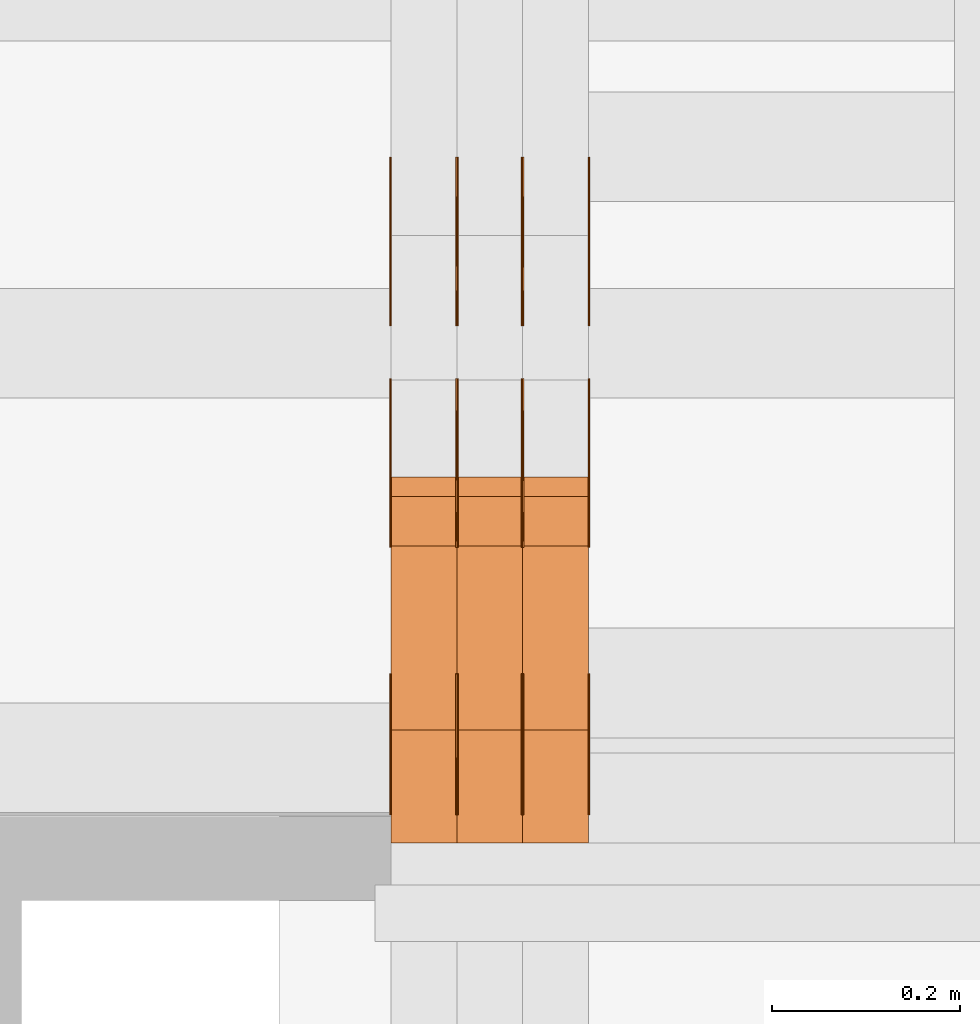
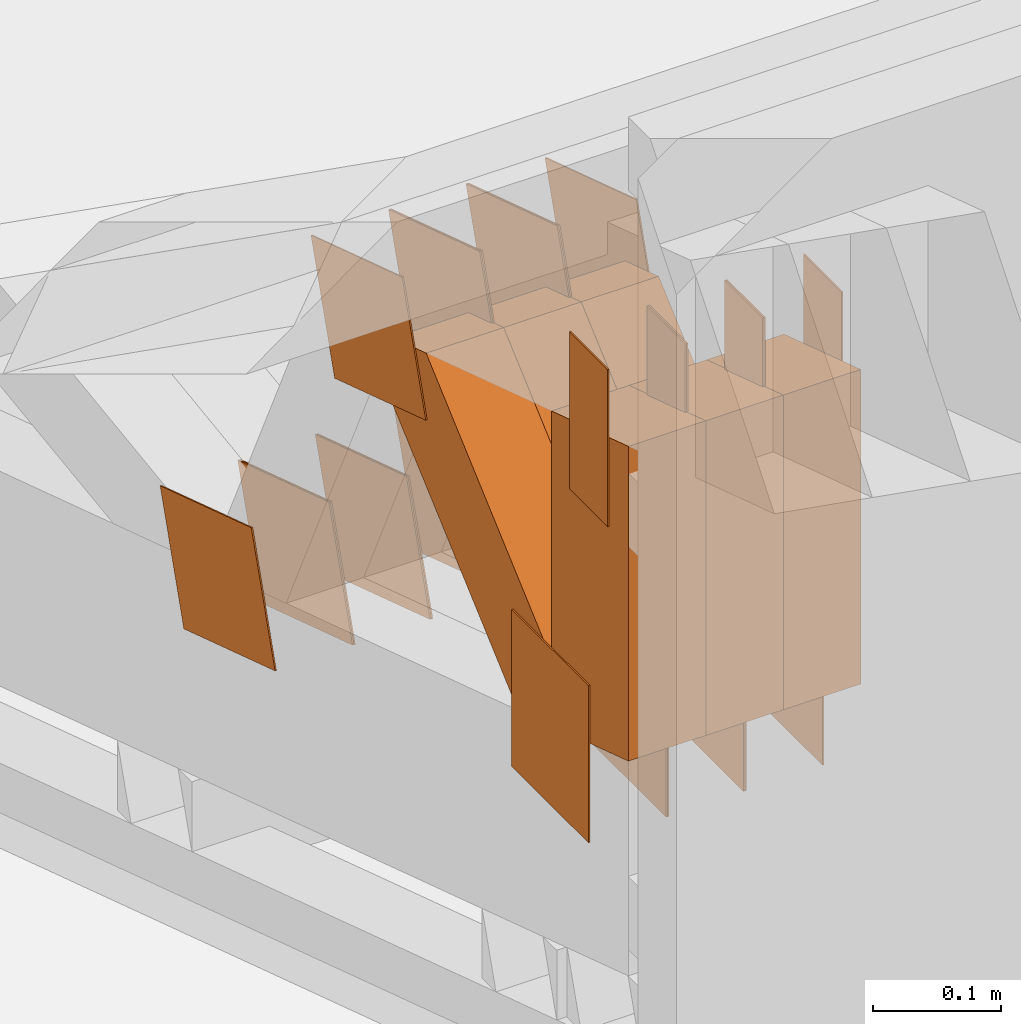
# One storey, part 82 of 385: 30 proxies.
"""IFC2X3 building model written with IfcOpenShell, lengths in millimetres."""

from ifc_helpers import new_model, entity, si_unit, converted_unit, derived_unit, direction, frame, origin, origin_2d_with_axis, place, context, subcontext, project, spatial, polyline, rectangle, outline, extrude, source, transform, mapped, material, type_object, type_shapes, element, save


model = new_model("IFC2X3")

# Units and contexts
model_context = context("Model", 3, precision=0.01, world=origin(), true_north=direction((6.12303176911189e-17, 1.0)))
body_context = subcontext(model_context, "Body", "Model", "MODEL_VIEW")
ifc_project = project(units=[si_unit("LENGTHUNIT", "METRE", prefix="MILLI"), si_unit("AREAUNIT", "SQUARE_METRE"), si_unit("VOLUMEUNIT", "CUBIC_METRE"), converted_unit("PLANEANGLEUNIT", "DEGREE", entity("IfcRatioMeasure", 0.0174532925199433), si_unit("PLANEANGLEUNIT", "RADIAN"), dimensions=[0, 0, 0, 0, 0, 0, 0]), si_unit("MASSUNIT", "GRAM", prefix="KILO"), derived_unit("MASSDENSITYUNIT", [(si_unit("MASSUNIT", "GRAM", prefix="KILO"), 1), (si_unit("LENGTHUNIT", "METRE"), -3)]), si_unit("TIMEUNIT", "SECOND"), si_unit("FREQUENCYUNIT", "HERTZ"), si_unit("THERMODYNAMICTEMPERATUREUNIT", "DEGREE_CELSIUS"), derived_unit("THERMALTRANSMITTANCEUNIT", [(si_unit("MASSUNIT", "GRAM", prefix="KILO"), 1), (si_unit("THERMODYNAMICTEMPERATUREUNIT", "KELVIN"), -1), (si_unit("TIMEUNIT", "SECOND"), -3)]), derived_unit("VOLUMETRICFLOWRATEUNIT", [(si_unit("LENGTHUNIT", "METRE"), 3), (si_unit("TIMEUNIT", "SECOND"), -1)]), si_unit("ELECTRICCURRENTUNIT", "AMPERE"), si_unit("ELECTRICVOLTAGEUNIT", "VOLT"), si_unit("POWERUNIT", "WATT"), si_unit("FORCEUNIT", "NEWTON", prefix="KILO"), si_unit("ILLUMINANCEUNIT", "LUX"), si_unit("LUMINOUSFLUXUNIT", "LUMEN"), si_unit("LUMINOUSINTENSITYUNIT", "CANDELA"), derived_unit("USERDEFINED", [(si_unit("MASSUNIT", "GRAM", prefix="KILO"), -1), (si_unit("LENGTHUNIT", "METRE"), -2), (si_unit("TIMEUNIT", "SECOND"), 3), (si_unit("LUMINOUSFLUXUNIT", "LUMEN"), 1)]), derived_unit("LINEARVELOCITYUNIT", [(si_unit("LENGTHUNIT", "METRE"), 1), (si_unit("TIMEUNIT", "SECOND"), -1)]), si_unit("PRESSUREUNIT", "PASCAL"), derived_unit("USERDEFINED", [(si_unit("LENGTHUNIT", "METRE"), -2), (si_unit("MASSUNIT", "GRAM", prefix="KILO"), 1), (si_unit("TIMEUNIT", "SECOND"), -2)])], contexts=[model_context])

# Site, building, storey
site_placement = place(None, origin())
site = spatial("IfcSite", under=ifc_project, at=site_placement, CompositionType="ELEMENT")
building_placement = place(site_placement, origin())
building = spatial("IfcBuilding", under=site, at=building_placement, CompositionType="ELEMENT")
storey_placement = place(building_placement, origin())
storey = spatial("IfcBuildingStorey", under=building, at=storey_placement, Name="Default", CompositionType="ELEMENT", Elevation=0.0)

# Proxies
ifc_material_1 = material(Name="IfcSurfaceStyle #33218")
building_element_proxy_type_1 = type_object("IfcBuildingElementProxyType", PredefinedType="NOTDEFINED", material=ifc_material_1)
shared_shape_1 = source(origin(), body_context, "Body", "SweptSolid", [
    extrude(rectangle(XDim=150.0, YDim=120.0, at=origin_2d_with_axis()), frame((75.0, 60.0, 0.0), z_axis=(0.0, 0.0, 1.0), x_axis=(-1.0, 0.0, 0.0)), (0.0, 0.0, 1.0), 1.3),
])
type_shapes(building_element_proxy_type_1, [shared_shape_1])
proxy_1_placement = place(building_placement, frame((386.299999999986, 15840.0, 3652.70166015625), z_axis=(-1.0, 0.0, 0.0), x_axis=(0.0, 0.0, -1.0)))
element("IfcBuildingElementProxy", 1, at=proxy_1_placement, inside=storey, type_object=building_element_proxy_type_1, material=ifc_material_1, context=body_context, shape_type="MappedRepresentation", body=[
    mapped(shared_shape_1, transform((0.0, 0.0, 0.0), scale=1.0)),
])
ifc_material_2 = material(Name="IfcSurfaceStyle #33161")
building_element_proxy_type_2 = type_object("IfcBuildingElementProxyType", PredefinedType="NOTDEFINED", material=ifc_material_2)
shared_shape_2 = source(origin(), body_context, "Body", "SweptSolid", [
    extrude(rectangle(XDim=150.0, YDim=120.0, at=origin_2d_with_axis()), frame((75.0, 60.0, 0.0), z_axis=(0.0, 0.0, 1.0), x_axis=(-1.0, 0.0, 0.0)), (0.0, 0.0, 1.0), 1.3),
])
type_shapes(building_element_proxy_type_2, [shared_shape_2])
proxy_2_placement = place(building_placement, frame((315.0, 15840.0, 3652.70166015625), z_axis=(-1.0, 0.0, 0.0), x_axis=(0.0, 0.0, -1.0)))
element("IfcBuildingElementProxy", 2, at=proxy_2_placement, inside=storey, type_object=building_element_proxy_type_2, material=ifc_material_2, context=body_context, shape_type="MappedRepresentation", body=[
    mapped(shared_shape_2, transform((0.0, 0.0, 0.0), scale=1.0)),
])
ifc_material_3 = material(Name="IfcSurfaceStyle #33104")
building_element_proxy_type_3 = type_object("IfcBuildingElementProxyType", PredefinedType="NOTDEFINED", material=ifc_material_3)
shared_shape_3 = source(origin(), body_context, "Body", "SweptSolid", [
    extrude(rectangle(XDim=150.0, YDim=120.0, at=origin_2d_with_axis()), frame((75.0, 60.0, 0.0), z_axis=(0.0, 0.0, 1.0), x_axis=(-1.0, 0.0, 0.0)), (0.0, 0.0, 1.0), 1.3),
])
type_shapes(building_element_proxy_type_3, [shared_shape_3])
proxy_3_placement = place(building_placement, frame((316.299999999986, 15840.0, 3652.70166015625), z_axis=(-1.0, 0.0, 0.0), x_axis=(0.0, 0.0, -1.0)))
element("IfcBuildingElementProxy", 3, at=proxy_3_placement, inside=storey, type_object=building_element_proxy_type_3, material=ifc_material_3, context=body_context, shape_type="MappedRepresentation", body=[
    mapped(shared_shape_3, transform((0.0, 0.0, 0.0), scale=1.0)),
])
ifc_material_4 = material(Name="IfcSurfaceStyle #33047")
building_element_proxy_type_4 = type_object("IfcBuildingElementProxyType", PredefinedType="NOTDEFINED", material=ifc_material_4)
shared_shape_4 = source(origin(), body_context, "Body", "SweptSolid", [
    extrude(rectangle(XDim=150.0, YDim=120.0, at=origin_2d_with_axis()), frame((75.0, 60.0, 0.0), z_axis=(0.0, 0.0, 1.0), x_axis=(-1.0, 0.0, 0.0)), (0.0, 0.0, 1.0), 1.29999999999999),
])
type_shapes(building_element_proxy_type_4, [shared_shape_4])
proxy_4_placement = place(building_placement, frame((245.0, 15840.0, 3652.70166015625), z_axis=(-1.0, 0.0, 0.0), x_axis=(0.0, 0.0, -1.0)))
element("IfcBuildingElementProxy", 4, at=proxy_4_placement, inside=storey, type_object=building_element_proxy_type_4, material=ifc_material_4, context=body_context, shape_type="MappedRepresentation", body=[
    mapped(shared_shape_4, transform((0.0, 0.0, 0.0), scale=1.0)),
])
ifc_material_5 = material(Name="IfcSurfaceStyle #32990")
building_element_proxy_type_5 = type_object("IfcBuildingElementProxyType", PredefinedType="NOTDEFINED", material=ifc_material_5)
shared_shape_5 = source(origin(), body_context, "Body", "SweptSolid", [
    extrude(rectangle(XDim=150.0, YDim=120.0, at=origin_2d_with_axis()), frame((75.0, 60.0, 0.0), z_axis=(0.0, 0.0, 1.0), x_axis=(-1.0, 0.0, 0.0)), (0.0, 0.0, 1.0), 1.29999999999999),
])
type_shapes(building_element_proxy_type_5, [shared_shape_5])
proxy_5_placement = place(building_placement, frame((246.299999999986, 15840.0, 3652.70166015625), z_axis=(-1.0, 0.0, 0.0), x_axis=(0.0, 0.0, -1.0)))
element("IfcBuildingElementProxy", 5, at=proxy_5_placement, inside=storey, type_object=building_element_proxy_type_5, material=ifc_material_5, context=body_context, shape_type="MappedRepresentation", body=[
    mapped(shared_shape_5, transform((0.0, 0.0, 0.0), scale=1.0)),
])
ifc_material_6 = material(Name="IfcSurfaceStyle #32933")
building_element_proxy_type_6 = type_object("IfcBuildingElementProxyType", PredefinedType="NOTDEFINED", material=ifc_material_6)
shared_shape_6 = source(origin(), body_context, "Body", "SweptSolid", [
    extrude(rectangle(XDim=150.0, YDim=120.0, at=origin_2d_with_axis()), frame((75.0, 60.0, 0.0), z_axis=(0.0, 0.0, 1.0), x_axis=(-1.0, 0.0, 0.0)), (0.0, 0.0, 1.0), 1.29999999999999),
])
type_shapes(building_element_proxy_type_6, [shared_shape_6])
proxy_6_placement = place(building_placement, frame((175.0, 15840.0, 3652.70166015625), z_axis=(-1.0, 0.0, 0.0), x_axis=(0.0, 0.0, -1.0)))
element("IfcBuildingElementProxy", 6, at=proxy_6_placement, inside=storey, type_object=building_element_proxy_type_6, material=ifc_material_6, context=body_context, shape_type="MappedRepresentation", body=[
    mapped(shared_shape_6, transform((0.0, 0.0, 0.0), scale=1.0)),
])
ifc_material_7 = material(Name="IfcSurfaceStyle #32876")
building_element_proxy_type_7 = type_object("IfcBuildingElementProxyType", PredefinedType="NOTDEFINED", material=ifc_material_7)
shared_shape_7 = source(origin(), body_context, "Body", "SweptSolid", [
    extrude(outline(polyline([(-74.9998605591118, -59.9999264677601), (74.9998754286171, -59.9999264677601), (74.9998605591118, 59.9999264677602), (-74.9998754286171, 59.9999264677602), (-74.9998605591118, -59.9999264677601)])), frame((74.9998754286171, 60.0000503992849, 0.0), z_axis=(0.0, 0.0, 1.0), x_axis=(-1.0, 0.0, 0.0)), (0.0, 0.0, 1.0), 1.3),
])
type_shapes(building_element_proxy_type_7, [shared_shape_7])
proxy_7_placement = place(building_placement, frame((386.299999999986, 16352.8320303235, 3323.23212676408), z_axis=(-1.0, 0.0, 0.0), x_axis=(0.0, -0.951056516295124, 0.309016994375039)))
element("IfcBuildingElementProxy", 7, at=proxy_7_placement, inside=storey, type_object=building_element_proxy_type_7, material=ifc_material_7, context=body_context, shape_type="MappedRepresentation", body=[
    mapped(shared_shape_7, transform((0.0, 0.0, 0.0), scale=1.0)),
])
ifc_material_8 = material(Name="IfcSurfaceStyle #32819")
building_element_proxy_type_8 = type_object("IfcBuildingElementProxyType", PredefinedType="NOTDEFINED", material=ifc_material_8)
shared_shape_8 = source(origin(), body_context, "Body", "SweptSolid", [
    extrude(outline(polyline([(-74.9998605591118, -59.9999264677601), (74.9998754286171, -59.9999264677601), (74.9998605591118, 59.9999264677602), (-74.9998754286171, 59.9999264677602), (-74.9998605591118, -59.9999264677601)])), frame((74.9998754286171, 60.0000503992849, 0.0), z_axis=(0.0, 0.0, 1.0), x_axis=(-1.0, 0.0, 0.0)), (0.0, 0.0, 1.0), 1.3),
])
type_shapes(building_element_proxy_type_8, [shared_shape_8])
proxy_8_placement = place(building_placement, frame((315.0, 16352.8320303235, 3323.23212676408), z_axis=(-1.0, 0.0, 0.0), x_axis=(0.0, -0.951056516295124, 0.309016994375039)))
element("IfcBuildingElementProxy", 8, at=proxy_8_placement, inside=storey, type_object=building_element_proxy_type_8, material=ifc_material_8, context=body_context, shape_type="MappedRepresentation", body=[
    mapped(shared_shape_8, transform((0.0, 0.0, 0.0), scale=1.0)),
])
ifc_material_9 = material(Name="IfcSurfaceStyle #32762")
building_element_proxy_type_9 = type_object("IfcBuildingElementProxyType", PredefinedType="NOTDEFINED", material=ifc_material_9)
shared_shape_9 = source(origin(), body_context, "Body", "SweptSolid", [
    extrude(outline(polyline([(-74.9998605591118, -59.9999264677601), (74.9998754286171, -59.9999264677601), (74.9998605591118, 59.9999264677602), (-74.9998754286171, 59.9999264677602), (-74.9998605591118, -59.9999264677601)])), frame((74.9998754286171, 60.0000503992849, 0.0), z_axis=(0.0, 0.0, 1.0), x_axis=(-1.0, 0.0, 0.0)), (0.0, 0.0, 1.0), 1.3),
])
type_shapes(building_element_proxy_type_9, [shared_shape_9])
proxy_9_placement = place(building_placement, frame((316.299999999986, 16352.8320303235, 3323.23212676408), z_axis=(-1.0, 0.0, 0.0), x_axis=(0.0, -0.951056516295124, 0.309016994375039)))
element("IfcBuildingElementProxy", 9, at=proxy_9_placement, inside=storey, type_object=building_element_proxy_type_9, material=ifc_material_9, context=body_context, shape_type="MappedRepresentation", body=[
    mapped(shared_shape_9, transform((0.0, 0.0, 0.0), scale=1.0)),
])
ifc_material_10 = material(Name="IfcSurfaceStyle #32705")
building_element_proxy_type_10 = type_object("IfcBuildingElementProxyType", PredefinedType="NOTDEFINED", material=ifc_material_10)
shared_shape_10 = source(origin(), body_context, "Body", "SweptSolid", [
    extrude(outline(polyline([(-74.9998605591118, -59.9999264677601), (74.9998754286171, -59.9999264677601), (74.9998605591118, 59.9999264677602), (-74.9998754286171, 59.9999264677602), (-74.9998605591118, -59.9999264677601)])), frame((74.9998754286171, 60.0000503992849, 0.0), z_axis=(0.0, 0.0, 1.0), x_axis=(-1.0, 0.0, 0.0)), (0.0, 0.0, 1.0), 1.29999999999999),
])
type_shapes(building_element_proxy_type_10, [shared_shape_10])
proxy_10_placement = place(building_placement, frame((245.0, 16352.8320303235, 3323.23212676408), z_axis=(-1.0, 0.0, 0.0), x_axis=(0.0, -0.951056516295124, 0.309016994375039)))
element("IfcBuildingElementProxy", 10, at=proxy_10_placement, inside=storey, type_object=building_element_proxy_type_10, material=ifc_material_10, context=body_context, shape_type="MappedRepresentation", body=[
    mapped(shared_shape_10, transform((0.0, 0.0, 0.0), scale=1.0)),
])
ifc_material_11 = material(Name="IfcSurfaceStyle #32648")
building_element_proxy_type_11 = type_object("IfcBuildingElementProxyType", PredefinedType="NOTDEFINED", material=ifc_material_11)
shared_shape_11 = source(origin(), body_context, "Body", "SweptSolid", [
    extrude(outline(polyline([(-74.9998605591118, -59.9999264677601), (74.9998754286171, -59.9999264677601), (74.9998605591118, 59.9999264677602), (-74.9998754286171, 59.9999264677602), (-74.9998605591118, -59.9999264677601)])), frame((74.9998754286171, 60.0000503992849, 0.0), z_axis=(0.0, 0.0, 1.0), x_axis=(-1.0, 0.0, 0.0)), (0.0, 0.0, 1.0), 1.29999999999999),
])
type_shapes(building_element_proxy_type_11, [shared_shape_11])
proxy_11_placement = place(building_placement, frame((246.299999999986, 16352.8320303235, 3323.23212676408), z_axis=(-1.0, 0.0, 0.0), x_axis=(0.0, -0.951056516295124, 0.309016994375039)))
element("IfcBuildingElementProxy", 11, at=proxy_11_placement, inside=storey, type_object=building_element_proxy_type_11, material=ifc_material_11, context=body_context, shape_type="MappedRepresentation", body=[
    mapped(shared_shape_11, transform((0.0, 0.0, 0.0), scale=1.0)),
])
ifc_material_12 = material(Name="IfcSurfaceStyle #32591")
building_element_proxy_type_12 = type_object("IfcBuildingElementProxyType", PredefinedType="NOTDEFINED", material=ifc_material_12)
shared_shape_12 = source(origin(), body_context, "Body", "SweptSolid", [
    extrude(outline(polyline([(-74.9998605591118, -59.9999264677601), (74.9998754286171, -59.9999264677601), (74.9998605591118, 59.9999264677602), (-74.9998754286171, 59.9999264677602), (-74.9998605591118, -59.9999264677601)])), frame((74.9998754286171, 60.0000503992849, 0.0), z_axis=(0.0, 0.0, 1.0), x_axis=(-1.0, 0.0, 0.0)), (0.0, 0.0, 1.0), 1.29999999999999),
])
type_shapes(building_element_proxy_type_12, [shared_shape_12])
proxy_12_placement = place(building_placement, frame((175.0, 16352.8320303235, 3323.23212676408), z_axis=(-1.0, 0.0, 0.0), x_axis=(0.0, -0.951056516295124, 0.309016994375039)))
element("IfcBuildingElementProxy", 12, at=proxy_12_placement, inside=storey, type_object=building_element_proxy_type_12, material=ifc_material_12, context=body_context, shape_type="MappedRepresentation", body=[
    mapped(shared_shape_12, transform((0.0, 0.0, 0.0), scale=1.0)),
])
ifc_material_13 = material(Name="IfcSurfaceStyle #28430")
building_element_proxy_type_13 = type_object("IfcBuildingElementProxyType", PredefinedType="NOTDEFINED", material=ifc_material_13)
shared_shape_13 = source(origin(), body_context, "Body", "SweptSolid", [
    extrude(outline(polyline([(-75.0003249421702, -60.0000773549573), (75.0003398116874, -60.0000773549573), (75.0003249421711, 60.0000773549573), (-75.0003398116883, 60.0000773549573), (-75.0003249421702, -60.0000773549573)])), frame((75.0003398116874, 60.0000773549573, 0.0), z_axis=(0.0, 0.0, 1.0), x_axis=(-1.0, 0.0, 0.0)), (0.0, 0.0, 1.0), 1.3),
])
type_shapes(building_element_proxy_type_13, [shared_shape_13])
proxy_13_placement = place(building_placement, frame((386.299999999986, 16117.0849050545, 3705.49074668796), z_axis=(-1.0, 0.0, 0.0), x_axis=(0.0, -0.951056516295154, 0.309016994374948)))
element("IfcBuildingElementProxy", 13, at=proxy_13_placement, inside=storey, type_object=building_element_proxy_type_13, material=ifc_material_13, context=body_context, shape_type="MappedRepresentation", body=[
    mapped(shared_shape_13, transform((0.0, 0.0, 0.0), scale=1.0)),
])
ifc_material_14 = material(Name="IfcSurfaceStyle #28373")
building_element_proxy_type_14 = type_object("IfcBuildingElementProxyType", PredefinedType="NOTDEFINED", material=ifc_material_14)
shared_shape_14 = source(origin(), body_context, "Body", "SweptSolid", [
    extrude(outline(polyline([(-75.0003249421702, -60.0000773549573), (75.0003398116874, -60.0000773549573), (75.0003249421711, 60.0000773549573), (-75.0003398116883, 60.0000773549573), (-75.0003249421702, -60.0000773549573)])), frame((75.0003398116874, 60.0000773549573, 0.0), z_axis=(0.0, 0.0, 1.0), x_axis=(-1.0, 0.0, 0.0)), (0.0, 0.0, 1.0), 1.3),
])
type_shapes(building_element_proxy_type_14, [shared_shape_14])
proxy_14_placement = place(building_placement, frame((315.0, 16117.0849050545, 3705.49074668796), z_axis=(-1.0, 0.0, 0.0), x_axis=(0.0, -0.951056516295154, 0.309016994374948)))
element("IfcBuildingElementProxy", 14, at=proxy_14_placement, inside=storey, type_object=building_element_proxy_type_14, material=ifc_material_14, context=body_context, shape_type="MappedRepresentation", body=[
    mapped(shared_shape_14, transform((0.0, 0.0, 0.0), scale=1.0)),
])
ifc_material_15 = material(Name="IfcSurfaceStyle #28316")
building_element_proxy_type_15 = type_object("IfcBuildingElementProxyType", PredefinedType="NOTDEFINED", material=ifc_material_15)
shared_shape_15 = source(origin(), body_context, "Body", "SweptSolid", [
    extrude(outline(polyline([(-75.0003249421702, -60.0000773549573), (75.0003398116874, -60.0000773549573), (75.0003249421711, 60.0000773549573), (-75.0003398116883, 60.0000773549573), (-75.0003249421702, -60.0000773549573)])), frame((75.0003398116874, 60.0000773549573, 0.0), z_axis=(0.0, 0.0, 1.0), x_axis=(-1.0, 0.0, 0.0)), (0.0, 0.0, 1.0), 1.3),
])
type_shapes(building_element_proxy_type_15, [shared_shape_15])
proxy_15_placement = place(building_placement, frame((316.299999999986, 16117.0849050545, 3705.49074668796), z_axis=(-1.0, 0.0, 0.0), x_axis=(0.0, -0.951056516295154, 0.309016994374948)))
element("IfcBuildingElementProxy", 15, at=proxy_15_placement, inside=storey, type_object=building_element_proxy_type_15, material=ifc_material_15, context=body_context, shape_type="MappedRepresentation", body=[
    mapped(shared_shape_15, transform((0.0, 0.0, 0.0), scale=1.0)),
])
ifc_material_16 = material(Name="IfcSurfaceStyle #28259")
building_element_proxy_type_16 = type_object("IfcBuildingElementProxyType", PredefinedType="NOTDEFINED", material=ifc_material_16)
shared_shape_16 = source(origin(), body_context, "Body", "SweptSolid", [
    extrude(outline(polyline([(-75.0003249421702, -60.0000773549573), (75.0003398116874, -60.0000773549573), (75.0003249421711, 60.0000773549573), (-75.0003398116883, 60.0000773549573), (-75.0003249421702, -60.0000773549573)])), frame((75.0003398116874, 60.0000773549573, 0.0), z_axis=(0.0, 0.0, 1.0), x_axis=(-1.0, 0.0, 0.0)), (0.0, 0.0, 1.0), 1.29999999999999),
])
type_shapes(building_element_proxy_type_16, [shared_shape_16])
proxy_16_placement = place(building_placement, frame((245.0, 16117.0849050545, 3705.49074668796), z_axis=(-1.0, 0.0, 0.0), x_axis=(0.0, -0.951056516295154, 0.309016994374948)))
element("IfcBuildingElementProxy", 16, at=proxy_16_placement, inside=storey, type_object=building_element_proxy_type_16, material=ifc_material_16, context=body_context, shape_type="MappedRepresentation", body=[
    mapped(shared_shape_16, transform((0.0, 0.0, 0.0), scale=1.0)),
])
ifc_material_17 = material(Name="IfcSurfaceStyle #28202")
building_element_proxy_type_17 = type_object("IfcBuildingElementProxyType", PredefinedType="NOTDEFINED", material=ifc_material_17)
shared_shape_17 = source(origin(), body_context, "Body", "SweptSolid", [
    extrude(outline(polyline([(-75.0003249421702, -60.0000773549573), (75.0003398116874, -60.0000773549573), (75.0003249421711, 60.0000773549573), (-75.0003398116883, 60.0000773549573), (-75.0003249421702, -60.0000773549573)])), frame((75.0003398116874, 60.0000773549573, 0.0), z_axis=(0.0, 0.0, 1.0), x_axis=(-1.0, 0.0, 0.0)), (0.0, 0.0, 1.0), 1.29999999999999),
])
type_shapes(building_element_proxy_type_17, [shared_shape_17])
proxy_17_placement = place(building_placement, frame((246.299999999986, 16117.0849050545, 3705.49074668796), z_axis=(-1.0, 0.0, 0.0), x_axis=(0.0, -0.951056516295154, 0.309016994374948)))
element("IfcBuildingElementProxy", 17, at=proxy_17_placement, inside=storey, type_object=building_element_proxy_type_17, material=ifc_material_17, context=body_context, shape_type="MappedRepresentation", body=[
    mapped(shared_shape_17, transform((0.0, 0.0, 0.0), scale=1.0)),
])
ifc_material_18 = material(Name="IfcSurfaceStyle #28145")
building_element_proxy_type_18 = type_object("IfcBuildingElementProxyType", PredefinedType="NOTDEFINED", material=ifc_material_18)
shared_shape_18 = source(origin(), body_context, "Body", "SweptSolid", [
    extrude(outline(polyline([(-75.0003249421702, -60.0000773549573), (75.0003398116874, -60.0000773549573), (75.0003249421711, 60.0000773549573), (-75.0003398116883, 60.0000773549573), (-75.0003249421702, -60.0000773549573)])), frame((75.0003398116874, 60.0000773549573, 0.0), z_axis=(0.0, 0.0, 1.0), x_axis=(-1.0, 0.0, 0.0)), (0.0, 0.0, 1.0), 1.29999999999999),
])
type_shapes(building_element_proxy_type_18, [shared_shape_18])
proxy_18_placement = place(building_placement, frame((175.0, 16117.0849050545, 3705.49074668796), z_axis=(-1.0, 0.0, 0.0), x_axis=(0.0, -0.951056516295154, 0.309016994374948)))
element("IfcBuildingElementProxy", 18, at=proxy_18_placement, inside=storey, type_object=building_element_proxy_type_18, material=ifc_material_18, context=body_context, shape_type="MappedRepresentation", body=[
    mapped(shared_shape_18, transform((0.0, 0.0, 0.0), scale=1.0)),
])
ifc_material_19 = material(Name="IfcSurfaceStyle #27746")
building_element_proxy_type_19 = type_object("IfcBuildingElementProxyType", PredefinedType="NOTDEFINED", material=ifc_material_19)
shared_shape_19 = source(origin(), body_context, "Body", "SweptSolid", [
    extrude(rectangle(XDim=150.0, YDim=60.0, at=origin_2d_with_axis()), frame((75.0000705696311, 30.0, 0.0), z_axis=(0.0, 0.0, 1.0), x_axis=(-1.0, 0.0, 0.0)), (0.0, 0.0, 1.0), 1.3),
])
type_shapes(building_element_proxy_type_19, [shared_shape_19])
proxy_19_placement = place(building_placement, frame((386.299999999986, 15750.0, 3972.59919166338), z_axis=(-1.0, 0.0, 0.0), x_axis=(0.0, 0.0, -1.0)))
element("IfcBuildingElementProxy", 19, at=proxy_19_placement, inside=storey, type_object=building_element_proxy_type_19, material=ifc_material_19, context=body_context, shape_type="MappedRepresentation", body=[
    mapped(shared_shape_19, transform((0.0, 0.0, 0.0), scale=1.0)),
])
ifc_material_20 = material(Name="IfcSurfaceStyle #27689")
building_element_proxy_type_20 = type_object("IfcBuildingElementProxyType", PredefinedType="NOTDEFINED", material=ifc_material_20)
shared_shape_20 = source(origin(), body_context, "Body", "SweptSolid", [
    extrude(rectangle(XDim=150.0, YDim=60.0, at=origin_2d_with_axis()), frame((75.0000705696311, 30.0, 0.0), z_axis=(0.0, 0.0, 1.0), x_axis=(-1.0, 0.0, 0.0)), (0.0, 0.0, 1.0), 1.3),
])
type_shapes(building_element_proxy_type_20, [shared_shape_20])
proxy_20_placement = place(building_placement, frame((315.0, 15750.0, 3972.59919166338), z_axis=(-1.0, 0.0, 0.0), x_axis=(0.0, 0.0, -1.0)))
element("IfcBuildingElementProxy", 20, at=proxy_20_placement, inside=storey, type_object=building_element_proxy_type_20, material=ifc_material_20, context=body_context, shape_type="MappedRepresentation", body=[
    mapped(shared_shape_20, transform((0.0, 0.0, 0.0), scale=1.0)),
])
ifc_material_21 = material(Name="IfcSurfaceStyle #27632")
building_element_proxy_type_21 = type_object("IfcBuildingElementProxyType", PredefinedType="NOTDEFINED", material=ifc_material_21)
shared_shape_21 = source(origin(), body_context, "Body", "SweptSolid", [
    extrude(rectangle(XDim=150.0, YDim=60.0, at=origin_2d_with_axis()), frame((75.0000705696311, 30.0, 0.0), z_axis=(0.0, 0.0, 1.0), x_axis=(-1.0, 0.0, 0.0)), (0.0, 0.0, 1.0), 1.3),
])
type_shapes(building_element_proxy_type_21, [shared_shape_21])
proxy_21_placement = place(building_placement, frame((316.299999999986, 15750.0, 3972.59919166338), z_axis=(-1.0, 0.0, 0.0), x_axis=(0.0, 0.0, -1.0)))
element("IfcBuildingElementProxy", 21, at=proxy_21_placement, inside=storey, type_object=building_element_proxy_type_21, material=ifc_material_21, context=body_context, shape_type="MappedRepresentation", body=[
    mapped(shared_shape_21, transform((0.0, 0.0, 0.0), scale=1.0)),
])
ifc_material_22 = material(Name="IfcSurfaceStyle #27575")
building_element_proxy_type_22 = type_object("IfcBuildingElementProxyType", PredefinedType="NOTDEFINED", material=ifc_material_22)
shared_shape_22 = source(origin(), body_context, "Body", "SweptSolid", [
    extrude(rectangle(XDim=150.0, YDim=60.0, at=origin_2d_with_axis()), frame((75.0000705696311, 30.0, 0.0), z_axis=(0.0, 0.0, 1.0), x_axis=(-1.0, 0.0, 0.0)), (0.0, 0.0, 1.0), 1.29999999999999),
])
type_shapes(building_element_proxy_type_22, [shared_shape_22])
proxy_22_placement = place(building_placement, frame((245.0, 15750.0, 3972.59919166338), z_axis=(-1.0, 0.0, 0.0), x_axis=(0.0, 0.0, -1.0)))
element("IfcBuildingElementProxy", 22, at=proxy_22_placement, inside=storey, type_object=building_element_proxy_type_22, material=ifc_material_22, context=body_context, shape_type="MappedRepresentation", body=[
    mapped(shared_shape_22, transform((0.0, 0.0, 0.0), scale=1.0)),
])
ifc_material_23 = material(Name="IfcSurfaceStyle #27518")
building_element_proxy_type_23 = type_object("IfcBuildingElementProxyType", PredefinedType="NOTDEFINED", material=ifc_material_23)
shared_shape_23 = source(origin(), body_context, "Body", "SweptSolid", [
    extrude(rectangle(XDim=150.0, YDim=60.0, at=origin_2d_with_axis()), frame((75.0000705696311, 30.0, 0.0), z_axis=(0.0, 0.0, 1.0), x_axis=(-1.0, 0.0, 0.0)), (0.0, 0.0, 1.0), 1.29999999999999),
])
type_shapes(building_element_proxy_type_23, [shared_shape_23])
proxy_23_placement = place(building_placement, frame((246.299999999986, 15750.0, 3972.59919166338), z_axis=(-1.0, 0.0, 0.0), x_axis=(0.0, 0.0, -1.0)))
element("IfcBuildingElementProxy", 23, at=proxy_23_placement, inside=storey, type_object=building_element_proxy_type_23, material=ifc_material_23, context=body_context, shape_type="MappedRepresentation", body=[
    mapped(shared_shape_23, transform((0.0, 0.0, 0.0), scale=1.0)),
])
ifc_material_24 = material(Name="IfcSurfaceStyle #27461")
building_element_proxy_type_24 = type_object("IfcBuildingElementProxyType", PredefinedType="NOTDEFINED", material=ifc_material_24)
shared_shape_24 = source(origin(), body_context, "Body", "SweptSolid", [
    extrude(rectangle(XDim=150.0, YDim=60.0, at=origin_2d_with_axis()), frame((75.0000705696311, 30.0, 0.0), z_axis=(0.0, 0.0, 1.0), x_axis=(-1.0, 0.0, 0.0)), (0.0, 0.0, 1.0), 1.29999999999999),
])
type_shapes(building_element_proxy_type_24, [shared_shape_24])
proxy_24_placement = place(building_placement, frame((175.0, 15750.0, 3972.59919166338), z_axis=(-1.0, 0.0, 0.0), x_axis=(0.0, 0.0, -1.0)))
element("IfcBuildingElementProxy", 24, at=proxy_24_placement, inside=storey, type_object=building_element_proxy_type_24, material=ifc_material_24, context=body_context, shape_type="MappedRepresentation", body=[
    mapped(shared_shape_24, transform((0.0, 0.0, 0.0), scale=1.0)),
])
ifc_material_25 = material(Name="IfcSurfaceStyle #18377")
building_element_proxy_type_25 = type_object("IfcBuildingElementProxyType", Name="T1-W50 18375", PredefinedType="NOTDEFINED", material=ifc_material_25)
shared_shape_25 = source(origin(), body_context, "Body", "SweptSolid", [
    extrude(outline(polyline([(-128.56619634284, -47.4999385885712), (133.151257249084, -47.4999385885712), (161.172800006526, -0.000129729183733609), (147.291467726413, 47.500068317755), (-142.513973767368, 47.500068317755), (-170.535354871815, -0.000129729183754689), (-128.56619634284, -47.4999385885712)])), frame((161.17310141218, 47.5001898716564, 0.0), z_axis=(0.0, 0.0, 1.0), x_axis=(-1.0, 0.0, 0.0)), (0.0, 0.0, 1.0), 70.0),
])
type_shapes(building_element_proxy_type_25, [shared_shape_25])
proxy_25_placement = place(building_placement, frame((385.0, 16060.0297689714, 3761.73994820667), z_axis=(-1.0, 0.0, 0.0), x_axis=(0.0, -0.749388407538668, -0.662130662820156)))
element("IfcBuildingElementProxy", 25, at=proxy_25_placement, inside=storey, type_object=building_element_proxy_type_25, material=ifc_material_25, Name="T1-W50", context=body_context, shape_type="MappedRepresentation", body=[
    mapped(shared_shape_25, transform((0.0, 0.0, 0.0), scale=1.0)),
])
ifc_material_26 = material(Name="IfcSurfaceStyle #18302")
building_element_proxy_type_26 = type_object("IfcBuildingElementProxyType", Name="T1-W50 18300", PredefinedType="NOTDEFINED", material=ifc_material_26)
shared_shape_26 = source(origin(), body_context, "Body", "SweptSolid", [
    extrude(outline(polyline([(-128.56619634284, -47.4999385885712), (133.151257249084, -47.4999385885712), (161.172800006526, -0.000129729183733609), (147.291467726413, 47.500068317755), (-142.513973767368, 47.500068317755), (-170.535354871815, -0.000129729183754689), (-128.56619634284, -47.4999385885712)])), frame((161.17310141218, 47.5001898716564, 0.0), z_axis=(0.0, 0.0, 1.0), x_axis=(-1.0, 0.0, 0.0)), (0.0, 0.0, 1.0), 70.0),
])
type_shapes(building_element_proxy_type_26, [shared_shape_26])
proxy_26_placement = place(building_placement, frame((315.0, 16060.0297689714, 3761.73994820667), z_axis=(-1.0, 0.0, 0.0), x_axis=(0.0, -0.749388407538668, -0.662130662820156)))
element("IfcBuildingElementProxy", 26, at=proxy_26_placement, inside=storey, type_object=building_element_proxy_type_26, material=ifc_material_26, Name="T1-W50", context=body_context, shape_type="MappedRepresentation", body=[
    mapped(shared_shape_26, transform((0.0, 0.0, 0.0), scale=1.0)),
])
ifc_material_27 = material(Name="IfcSurfaceStyle #18227")
building_element_proxy_type_27 = type_object("IfcBuildingElementProxyType", Name="T1-W50 18225", PredefinedType="NOTDEFINED", material=ifc_material_27)
shared_shape_27 = source(origin(), body_context, "Body", "SweptSolid", [
    extrude(outline(polyline([(-128.56619634284, -47.4999385885712), (133.151257249084, -47.4999385885712), (161.172800006526, -0.000129729183733609), (147.291467726413, 47.500068317755), (-142.513973767368, 47.500068317755), (-170.535354871815, -0.000129729183754689), (-128.56619634284, -47.4999385885712)])), frame((161.17310141218, 47.5001898716564, 0.0), z_axis=(0.0, 0.0, 1.0), x_axis=(-1.0, 0.0, 0.0)), (0.0, 0.0, 1.0), 70.0),
])
type_shapes(building_element_proxy_type_27, [shared_shape_27])
proxy_27_placement = place(building_placement, frame((245.0, 16060.0297689714, 3761.73994820667), z_axis=(-1.0, 0.0, 0.0), x_axis=(0.0, -0.749388407538668, -0.662130662820156)))
element("IfcBuildingElementProxy", 27, at=proxy_27_placement, inside=storey, type_object=building_element_proxy_type_27, material=ifc_material_27, Name="T1-W50", context=body_context, shape_type="MappedRepresentation", body=[
    mapped(shared_shape_27, transform((0.0, 0.0, 0.0), scale=1.0)),
])
ifc_material_28 = material(Name="IfcSurfaceStyle #17981")
building_element_proxy_type_28 = type_object("IfcBuildingElementProxyType", Name="T1-W2 17979", PredefinedType="NOTDEFINED", material=ifc_material_28)
shared_shape_28 = source(origin(), body_context, "Body", "SweptSolid", [
    extrude(outline(polyline([(-130.705993652344, -60.0), (169.696350097656, -60.0), (130.706115722656, 60.0), (-169.696472167969, 60.0), (-130.705993652344, -60.0)])), frame((169.696429629256, 60.0, 0.0), z_axis=(0.0, 0.0, 1.0), x_axis=(-1.0, 0.0, 0.0)), (0.0, 0.0, 1.0), 70.0),
])
type_shapes(building_element_proxy_type_28, [shared_shape_28])
proxy_28_placement = place(building_placement, frame((385.0, 15660.0, 3577.70158062465), z_axis=(-1.0, 0.0, 0.0), x_axis=(0.0, 0.0, 1.0)))
element("IfcBuildingElementProxy", 28, at=proxy_28_placement, inside=storey, type_object=building_element_proxy_type_28, material=ifc_material_28, Name="T1-W2", context=body_context, shape_type="MappedRepresentation", body=[
    mapped(shared_shape_28, transform((0.0, 0.0, 0.0), scale=1.0)),
])
ifc_material_29 = material(Name="IfcSurfaceStyle #17924")
building_element_proxy_type_29 = type_object("IfcBuildingElementProxyType", Name="T1-W2 17922", PredefinedType="NOTDEFINED", material=ifc_material_29)
shared_shape_29 = source(origin(), body_context, "Body", "SweptSolid", [
    extrude(outline(polyline([(-130.705993652344, -60.0), (169.696350097656, -60.0), (130.706115722656, 60.0), (-169.696472167969, 60.0), (-130.705993652344, -60.0)])), frame((169.696429629256, 60.0, 0.0), z_axis=(0.0, 0.0, 1.0), x_axis=(-1.0, 0.0, 0.0)), (0.0, 0.0, 1.0), 70.0),
])
type_shapes(building_element_proxy_type_29, [shared_shape_29])
proxy_29_placement = place(building_placement, frame((315.0, 15660.0, 3577.70158062465), z_axis=(-1.0, 0.0, 0.0), x_axis=(0.0, 0.0, 1.0)))
element("IfcBuildingElementProxy", 29, at=proxy_29_placement, inside=storey, type_object=building_element_proxy_type_29, material=ifc_material_29, Name="T1-W2", context=body_context, shape_type="MappedRepresentation", body=[
    mapped(shared_shape_29, transform((0.0, 0.0, 0.0), scale=1.0)),
])
ifc_material_30 = material(Name="IfcSurfaceStyle #17867")
building_element_proxy_type_30 = type_object("IfcBuildingElementProxyType", Name="T1-W2 17865", PredefinedType="NOTDEFINED", material=ifc_material_30)
shared_shape_30 = source(origin(), body_context, "Body", "SweptSolid", [
    extrude(outline(polyline([(-130.705993652344, -60.0), (169.696350097656, -60.0), (130.706115722656, 60.0), (-169.696472167969, 60.0), (-130.705993652344, -60.0)])), frame((169.696429629256, 60.0, 0.0), z_axis=(0.0, 0.0, 1.0), x_axis=(-1.0, 0.0, 0.0)), (0.0, 0.0, 1.0), 70.0),
])
type_shapes(building_element_proxy_type_30, [shared_shape_30])
proxy_30_placement = place(building_placement, frame((245.0, 15660.0, 3577.70158062465), z_axis=(-1.0, 0.0, 0.0), x_axis=(0.0, 0.0, 1.0)))
element("IfcBuildingElementProxy", 30, at=proxy_30_placement, inside=storey, type_object=building_element_proxy_type_30, material=ifc_material_30, Name="T1-W2", context=body_context, shape_type="MappedRepresentation", body=[
    mapped(shared_shape_30, transform((0.0, 0.0, 0.0), scale=1.0)),
])

save(model, "model.ifc")
